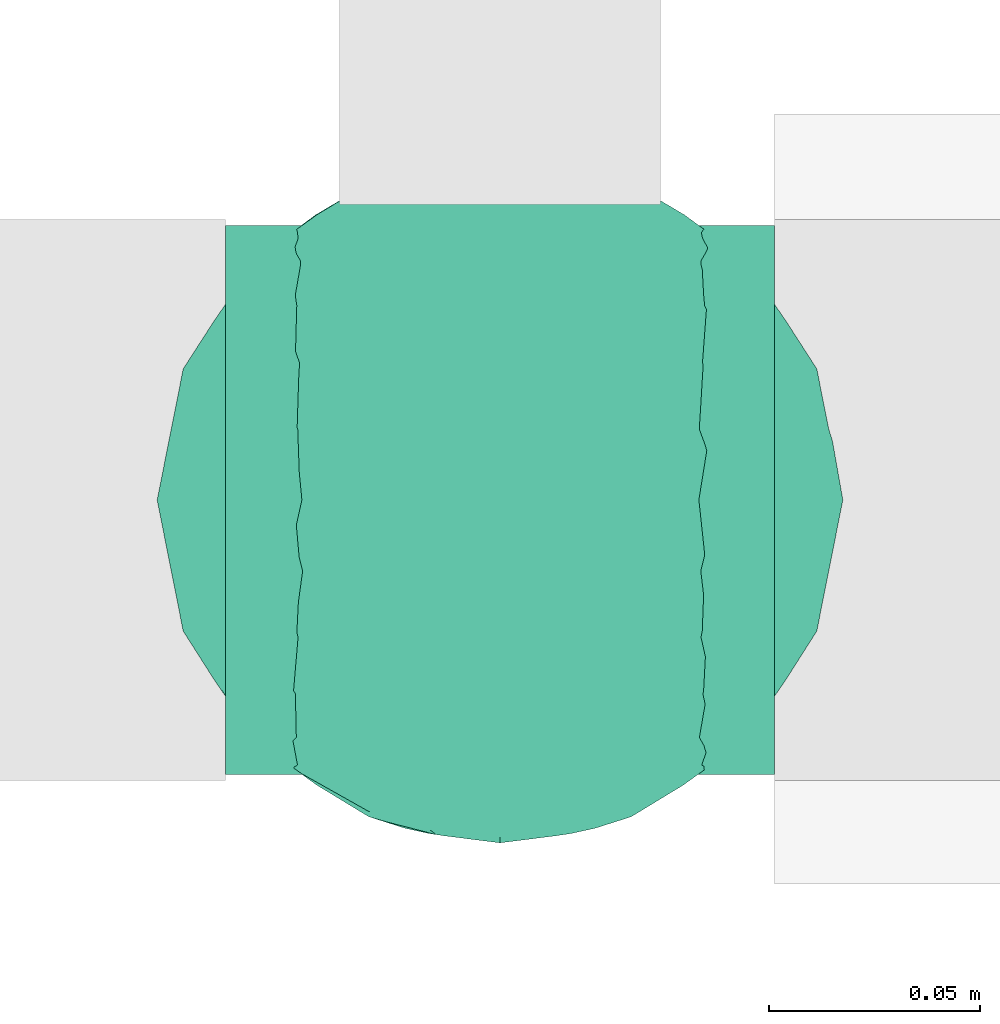
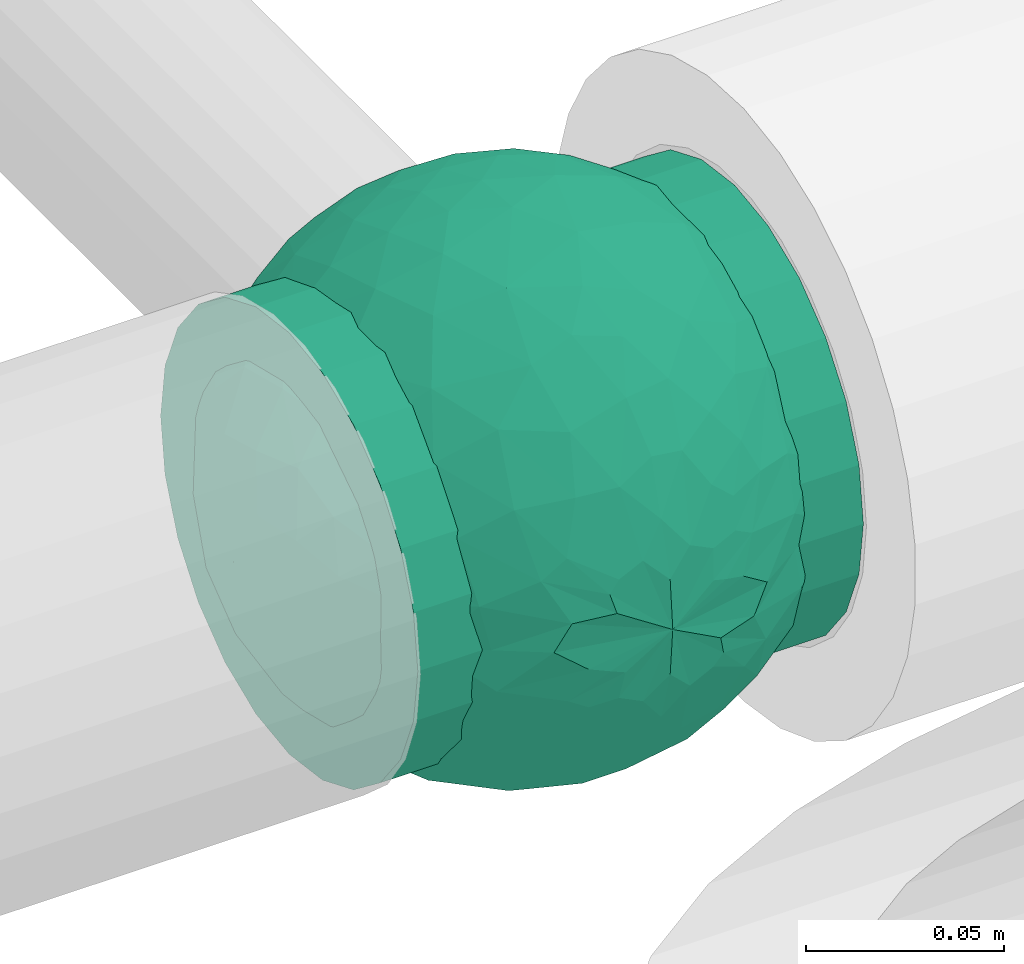
# One storey, part 784 of 827: 1 flow fitting.
"""IFC2X3 building model written with IfcOpenShell, lengths in millimetres."""

from ifc_helpers import new_model, entity, si_unit, converted_unit, derived_unit, direction, frame, origin, place, context, subcontext, project, spatial, faceted_brep, source, transform, mapped, material, material_list, type_object, type_shapes, element, save


model = new_model("IFC2X3")

# Units and contexts
model_context = context("Model", 3, precision=0.01, world=origin(), true_north=direction((6.12303176911189e-17, 1.0)))
body_context = subcontext(model_context, "Body", "Model", "MODEL_VIEW")
ifc_project = project(units=[si_unit("LENGTHUNIT", "METRE", prefix="MILLI"), si_unit("AREAUNIT", "SQUARE_METRE"), si_unit("VOLUMEUNIT", "CUBIC_METRE"), converted_unit("PLANEANGLEUNIT", "DEGREE", entity("IfcRatioMeasure", 0.0174532925199433), si_unit("PLANEANGLEUNIT", "RADIAN"), dimensions=[0, 0, 0, 0, 0, 0, 0]), si_unit("MASSUNIT", "GRAM", prefix="KILO"), derived_unit("MASSDENSITYUNIT", [(si_unit("MASSUNIT", "GRAM", prefix="KILO"), 1), (si_unit("LENGTHUNIT", "METRE"), -3)]), derived_unit("MOMENTOFINERTIAUNIT", [(si_unit("LENGTHUNIT", "METRE"), 4)]), si_unit("TIMEUNIT", "SECOND"), si_unit("FREQUENCYUNIT", "HERTZ"), si_unit("THERMODYNAMICTEMPERATUREUNIT", "DEGREE_CELSIUS"), derived_unit("THERMALTRANSMITTANCEUNIT", [(si_unit("MASSUNIT", "GRAM", prefix="KILO"), 1), (si_unit("THERMODYNAMICTEMPERATUREUNIT", "KELVIN"), -1), (si_unit("TIMEUNIT", "SECOND"), -3)]), derived_unit("VOLUMETRICFLOWRATEUNIT", [(si_unit("LENGTHUNIT", "METRE"), 3), (si_unit("TIMEUNIT", "SECOND"), -1)]), derived_unit("MASSFLOWRATEUNIT", [(si_unit("MASSUNIT", "GRAM", prefix="KILO"), 1), (si_unit("TIMEUNIT", "SECOND"), -1)]), derived_unit("ROTATIONALFREQUENCYUNIT", [(si_unit("TIMEUNIT", "SECOND"), -1)]), si_unit("ELECTRICCURRENTUNIT", "AMPERE"), si_unit("ELECTRICVOLTAGEUNIT", "VOLT"), si_unit("POWERUNIT", "WATT"), si_unit("FORCEUNIT", "NEWTON", prefix="KILO"), si_unit("ILLUMINANCEUNIT", "LUX"), si_unit("LUMINOUSFLUXUNIT", "LUMEN"), si_unit("LUMINOUSINTENSITYUNIT", "CANDELA"), derived_unit("USERDEFINED", [(si_unit("MASSUNIT", "GRAM", prefix="KILO"), -1), (si_unit("LENGTHUNIT", "METRE"), -2), (si_unit("TIMEUNIT", "SECOND"), 3), (si_unit("LUMINOUSFLUXUNIT", "LUMEN"), 1)]), derived_unit("LINEARVELOCITYUNIT", [(si_unit("LENGTHUNIT", "METRE"), 1), (si_unit("TIMEUNIT", "SECOND"), -1)]), si_unit("PRESSUREUNIT", "PASCAL"), derived_unit("USERDEFINED", [(si_unit("LENGTHUNIT", "METRE"), -2), (si_unit("MASSUNIT", "GRAM", prefix="KILO"), 1), (si_unit("TIMEUNIT", "SECOND"), -2)]), derived_unit("LINEARFORCEUNIT", [(si_unit("MASSUNIT", "GRAM", prefix="KILO"), 1), (si_unit("LENGTHUNIT", "METRE"), 1), (si_unit("TIMEUNIT", "SECOND"), -2), (si_unit("LENGTHUNIT", "METRE"), -1)]), derived_unit("PLANARFORCEUNIT", [(si_unit("MASSUNIT", "GRAM", prefix="KILO"), 1), (si_unit("LENGTHUNIT", "METRE"), 1), (si_unit("TIMEUNIT", "SECOND"), -2), (si_unit("LENGTHUNIT", "METRE"), -2)])], contexts=[model_context])

# Site, building, storey
site_placement = place(None, origin())
site = spatial("IfcSite", under=ifc_project, at=site_placement, CompositionType="ELEMENT")
building_placement = place(site_placement, origin())
building = spatial("IfcBuilding", under=site, at=building_placement, CompositionType="ELEMENT")
storey_placement = place(building_placement, frame((0.0, 0.0, 28200.0)))
storey = spatial("IfcBuildingStorey", under=building, at=storey_placement, Name="08", CompositionType="ELEMENT", Elevation=28200.0)

# Flow fitting
ifc_material_1 = material()
ifc_material_2 = material(Name="ADSK_")
ifc_material_list = material_list([ifc_material_1, ifc_material_2])
pipe_fitting_type = type_object("IfcPipeFittingType", Name="ADSK_2", PredefinedType="NOTDEFINED", material=ifc_material_list)
shared_shape = source(origin(), body_context, "Body", "Brep", [
    faceted_brep([(-65.0, 32.5, -56.29), (-65.0, 16.82, -62.79), (-65.0, 0.0, -65.0), (-65.0, -16.82, -62.79), (-65.0, -32.5, -56.29), (-65.0, -45.96, -45.96), (-65.0, -56.29, -32.5), (-65.0, -59.54, -24.66), (-65.0, -62.79, -16.82), (-65.0, -63.89, -8.41), (-65.0, -65.0, 0.0), (-65.0, -63.89, 8.41), (-65.0, -62.79, 16.82), (-65.0, -59.54, 24.66), (-65.0, -56.29, 32.5), (-65.0, -45.96, 45.96), (-65.0, -32.5, 56.29), (-65.0, -16.82, 62.79), (-65.0, 0.0, 65.0), (-65.0, 16.82, 62.79), (-65.0, 32.5, 56.29), (-65.0, 45.96, 45.96), (-65.0, 56.29, 32.5), (-65.0, 62.79, 16.82), (-65.0, 65.0, 0.0), (-65.0, 62.79, -16.82), (-65.0, 56.29, -32.5), (-65.0, 45.96, -45.96), (65.0, 0.0, -65.0), (65.0, 16.82, -62.79), (65.0, 32.5, -56.29), (65.0, 45.96, -45.96), (65.0, 56.29, -32.5), (65.0, 62.79, -16.82), (65.0, 65.0, 0.0), (65.0, 62.79, 16.82), (65.0, 56.29, 32.5), (65.0, 45.96, 45.96), (65.0, 32.5, 56.29), (65.0, 16.82, 62.79), (65.0, 0.0, 65.0), (65.0, -16.82, 62.79), (65.0, -32.5, 56.29), (65.0, -45.96, 45.96), (65.0, -56.29, 32.5), (65.0, -59.54, 24.66), (65.0, -62.79, 16.82), (65.0, -63.89, 8.41), (65.0, -65.0, 0.0), (65.0, -63.89, -8.41), (65.0, -62.79, -16.82), (65.0, -59.54, -24.66), (65.0, -56.29, -32.5), (65.0, -45.96, -45.96), (65.0, -32.5, -56.29), (65.0, -16.82, -62.79), (32.82, -63.85, 12.15), (33.91, -64.43, 6.07), (26.75, -60.95, 22.58), (29.78, -62.4, 17.36), (6.19, -55.12, 34.45), (35.0, -65.0, 0.0), (17.61, -57.53, 30.24), (11.9, -56.33, 32.35), (-17.62, -57.54, 30.24), (-26.75, -60.96, 22.57), (-32.82, -63.86, 12.15), (-33.91, -64.43, 6.07), (-35.0, -65.0, 0.0), (-29.79, -62.41, 17.36), (-11.91, -56.33, 32.35), (-6.2, -55.12, 34.45), (-0.01, -55.12, 34.45), (33.91, -64.43, -6.07), (32.82, -63.85, -12.15), (6.19, -55.12, -34.45), (-33.91, -64.43, -6.07), (17.61, -57.53, -30.24), (11.9, -56.33, -32.35), (29.78, -62.4, -17.36), (26.75, -60.95, -22.58), (-6.2, -55.12, -34.45), (-11.91, -56.33, -32.35), (-17.62, -57.54, -30.24), (-26.75, -60.96, -22.57), (-0.01, -55.12, -34.45), (-29.79, -62.41, -17.36), (-32.82, -63.86, -12.15), (0.0, -70.0, -35.0), (9.06, -70.0, -33.81), (17.5, -70.0, -30.31), (24.75, -70.0, -24.75), (30.31, -70.0, -17.5), (33.81, -70.0, -9.06), (35.0, -70.0, 0.0), (33.81, -70.0, 9.06), (30.31, -70.0, 17.5), (24.75, -70.0, 24.75), (17.5, -70.0, 30.31), (9.06, -70.0, 33.81), (0.0, -70.0, 35.0), (-9.06, -70.0, 33.81), (-17.5, -70.0, 30.31), (-24.75, -70.0, 24.75), (-30.31, -70.0, 17.5), (-33.81, -70.0, 9.06), (-35.0, -70.0, 0.0), (-33.81, -70.0, -9.06), (-30.31, -70.0, -17.5), (-24.75, -70.0, -24.75), (-17.5, -70.0, -30.31), (-9.06, -70.0, -33.81)], [[[0, 1, 2, 3, 4, 5, 6, 7, 8, 9, 10, 11, 12, 13, 14, 15, 16, 17, 18, 19, 20, 21, 22, 23, 24, 25, 26, 27]], [[28, 29, 30, 31, 32, 33, 34, 35, 36, 37, 38, 39, 40, 41, 42, 43, 44, 45, 46, 47, 48, 49, 50, 51, 52, 53, 54, 55]], [[47, 46, 56]], [[48, 47, 57]], [[46, 58, 59, 56]], [[44, 43, 60]], [[48, 57, 61]], [[58, 45, 62]], [[44, 60, 63, 62]], [[47, 56, 57]], [[43, 15, 60]], [[62, 45, 44]], [[64, 13, 65]], [[66, 11, 67]], [[68, 67, 10]], [[12, 66, 69, 65]], [[14, 64, 70, 71]], [[58, 46, 45]], [[14, 13, 64]], [[14, 71, 15]], [[65, 13, 12]], [[15, 71, 72, 60]], [[10, 67, 11]], [[66, 12, 11]], [[43, 42, 16, 15]], [[18, 17, 41, 40]], [[17, 16, 42, 41]], [[19, 18, 40, 39]], [[36, 35, 23, 22]], [[21, 20, 38, 37]], [[22, 21, 37, 36]], [[39, 38, 20, 19]], [[24, 23, 35, 34]], [[24, 34, 33, 25]], [[26, 32, 31, 27]], [[48, 73, 49]], [[25, 33, 32, 26]], [[28, 55, 3, 2]], [[1, 0, 30, 29]], [[2, 1, 29, 28]], [[30, 0, 27, 31]], [[54, 4, 3, 55]], [[74, 50, 49]], [[54, 53, 5, 4]], [[53, 52, 75]], [[10, 76, 68]], [[52, 77, 78, 75]], [[51, 77, 52]], [[53, 75, 5]], [[61, 73, 48]], [[50, 74, 79, 80]], [[74, 49, 73]], [[77, 51, 80]], [[50, 80, 51]], [[6, 81, 82, 83]], [[84, 8, 7]], [[6, 5, 81]], [[84, 7, 83]], [[5, 75, 85, 81]], [[8, 84, 86, 87]], [[9, 87, 76]], [[87, 9, 8]], [[76, 10, 9]], [[7, 6, 83]], [[88, 89, 90, 91, 92, 93, 94, 95, 96, 97, 98, 99, 100, 101, 102, 103, 104, 105, 106, 107, 108, 109, 110, 111]], [[106, 105, 67]], [[65, 104, 103]], [[105, 104, 66]], [[103, 102, 64]], [[94, 57, 95]], [[106, 67, 68]], [[66, 104, 65, 69]], [[70, 64, 102]], [[64, 65, 103]], [[100, 60, 72, 71]], [[63, 60, 99]], [[101, 70, 102]], [[63, 98, 62]], [[101, 71, 70]], [[60, 100, 99]], [[100, 71, 101]], [[58, 97, 96]], [[98, 97, 62]], [[56, 96, 95]], [[98, 63, 99]], [[97, 58, 62]], [[105, 66, 67]], [[95, 57, 56]], [[59, 58, 96, 56]], [[57, 94, 61]], [[94, 93, 73]], [[80, 92, 91]], [[93, 92, 74]], [[91, 90, 77]], [[106, 76, 107]], [[94, 73, 61]], [[74, 92, 80, 79]], [[78, 77, 90]], [[77, 80, 91]], [[88, 81, 85, 75]], [[82, 81, 111]], [[89, 78, 90]], [[82, 110, 83]], [[89, 75, 78]], [[81, 88, 111]], [[88, 75, 89]], [[108, 84, 109]], [[109, 83, 110]], [[107, 87, 108]], [[110, 82, 111]], [[109, 84, 83]], [[93, 74, 73]], [[107, 76, 87]], [[86, 84, 108, 87]], [[76, 106, 68]]]),
    faceted_brep([(-26.57, 76.36, -8.07), (-32.83, 71.49, -20.33), (-47.03, 64.85, -13.55), (22.24, -77.88, -6.48), (0.0, -81.25, 0.0), (14.57, -79.42, -9.02), (-19.55, 43.65, -65.68), (-6.7, 41.88, -69.3), (-15.5, 23.94, -76.08), (15.55, -78.16, 0.0), (20.63, -67.73, -39.86), (17.31, -55.39, -56.87), (33.39, -55.07, -49.54), (6.89, -77.99, -21.73), (13.76, -77.98, -18.22), (0.0, -79.9, -14.73), (-69.67, 30.72, -28.35), (-63.35, 45.14, -23.48), (-60.56, 38.81, -37.79), (-44.27, 66.26, 0.0), (8.9, -68.68, -42.49), (0.0, -57.53, -57.37), (-48.93, 45.14, -46.58), (-49.03, 57.11, -30.6), (-35.46, 62.54, -37.85), (76.18, -1.07, -28.23), (78.6, -12.72, -16.17), (71.53, -15.85, -35.12), (10.46, 67.82, -43.51), (0.0, 75.3, -30.53), (6.86, 78.01, -21.66), (-10.53, -67.73, -43.64), (0.0, -75.25, -30.63), (-6.89, -77.99, -21.73), (0.0, 81.25, 0.0), (15.55, 78.16, 0.0), (22.61, 77.77, -6.46), (-12.72, -56.34, -57.14), (-5.46, -45.53, -67.07), (44.37, 62.32, -27.38), (43.44, 67.56, -12.26), (56.18, 55.82, -18.18), (-13.79, 77.96, -18.26), (-25.89, 72.59, -25.72), (-16.58, 78.16, -14.76), (75.07, 31.09, 0.0), (74.86, 27.47, -15.59), (67.53, 42.93, -14.07), (13.79, 77.96, -18.26), (12.84, 79.64, -9.7), (21.38, 75.85, -19.79), (74.72, 15.85, -27.69), (79.59, 7.96, -14.27), (43.73, -67.56, -11.18), (57.45, -57.45, 0.0), (44.27, -66.26, 0.0), (63.35, -45.14, -23.48), (61.82, -51.54, -11.09), (49.12, -59.87, -24.59), (78.16, 15.55, 0.0), (50.83, -12.03, -62.24), (35.62, -9.55, -72.4), (43.7, 11.32, -67.56), (72.48, -29.04, -22.46), (-44.38, -62.32, -27.37), (-26.83, -74.87, -16.61), (-43.44, -67.56, -12.26), (-13.76, -77.98, -18.22), (-12.85, -79.64, -9.7), (-21.39, -75.84, -19.81), (-2.49, -31.04, -75.05), (8.59, -44.22, -67.62), (-74.72, -15.85, -27.69), (-68.67, -30.94, -30.47), (-74.55, -27.6, -16.8), (-75.07, 31.09, 0.0), (-71.41, 36.12, -14.04), (-75.88, 22.59, -18.27), (-22.61, -77.77, -6.46), (-16.87, -79.04, -8.34), (28.21, -26.53, -71.43), (13.03, -29.67, -74.51), (18.2, -9.78, -78.58), (-56.42, -55.66, -17.92), (6.0, 45.8, -66.84), (0.0, 57.69, -57.22), (-78.16, -15.55, 0.0), (-79.59, -7.96, -14.27), (32.83, -71.49, -20.33), (-15.55, -78.16, 0.0), (-20.62, 67.82, -39.72), (-33.11, 50.34, -54.51), (-61.82, 51.54, -11.09), (-66.26, 44.27, 0.0), (75.07, -31.09, 0.0), (66.26, -44.27, 0.0), (-6.86, 78.01, -21.66), (0.0, 79.92, -14.67), (26.82, 74.88, -16.61), (16.85, 79.04, -8.33), (-8.98, 69.99, -40.29), (38.78, -61.98, -35.46), (48.93, -45.14, -46.58), (55.26, -48.62, -34.41), (-71.53, 15.85, -35.12), (-78.76, 7.96, -18.29), (-17.06, 58.9, -53.31), (-15.55, 78.16, 0.0), (13.32, 55.85, -57.49), (21.86, 61.99, -47.75), (-15.13, 79.31, -9.05), (26.19, -72.28, -26.28), (17.27, -77.87, -15.49), (-29.57, -28.73, -70.02), (-26.25, -43.22, -63.6), (-42.18, -36.82, -58.88), (41.25, 41.74, -56.2), (54.79, 33.3, -49.91), (40.91, 28.53, -64.14), (38.98, -38.31, -60.12), (52.67, -28.88, -54.71), (68.84, 3.22, -43.04), (66.02, 21.29, -42.31), (-42.82, 33.53, -60.37), (-55.21, 10.46, -58.69), (-57.08, 27.98, -50.61), (-56.33, -15.85, -56.37), (-55.8, -33.3, -48.77), (-66.18, -20.5, -42.45), (31.09, 75.07, 0.0), (44.27, 66.26, 0.0), (57.45, 57.45, 0.0), (-31.09, -75.07, 0.0), (-57.45, -57.45, 0.0), (1.56, 67.82, -44.72), (-1.57, -67.73, -44.86), (22.55, 72.77, -28.25), (16.53, 72.17, -33.48), (-22.52, -72.77, -28.27), (-16.58, -72.47, -32.79), (28.96, -66.23, -37.11), (62.57, -34.08, -39.05), (62.37, -15.41, -49.74), (68.82, 31.09, -29.97), (-66.06, -1.38, -47.28), (-67.87, -42.27, -14.43), (29.1, 65.34, -38.54), (33.22, 68.08, -29.37), (46.02, 49.13, -45.5), (10.35, 15.34, -79.12), (0.0, 0.22, -81.25), (-29.12, -65.31, -38.57), (-22.07, -61.55, -48.23), (-33.19, -68.12, -29.33), (-46.02, -49.17, -45.45), (-34.11, 19.17, -71.21), (-23.02, 4.97, -77.76), (-40.38, 0.85, -70.5), (2.47, 31.35, -74.92), (16.3, 35.47, -71.26), (-13.73, -8.11, -79.67), (-28.12, -13.42, -75.04), (33.83, 54.01, -50.4), (26.1, 43.46, -63.49), (24.94, -42.3, -64.73), (-16.13, -35.64, -71.21), (0.28, -15.85, -79.69), (-13.57, -22.47, -76.89), (60.35, 45.14, -30.37), (-60.34, -45.14, -30.38), (-33.99, -54.1, -50.2), (-57.45, 57.45, 0.0), (-42.67, -18.04, -66.75), (-63.99, 15.14, -47.72), (-81.25, 0.0, 0.0), (-78.16, 15.55, 0.0), (-74.66, 0.0, -32.06), (-31.09, 75.07, 0.0), (31.09, -75.07, 0.0), (56.37, 15.85, -56.33), (28.0, 13.82, -75.01), (66.26, 44.27, 0.0), (81.25, 0.0, 0.0), (78.16, -15.55, 0.0), (-66.26, -44.27, 0.0), (-75.07, -31.09, 0.0), (-44.27, -66.26, 0.0), (26.57, 76.36, 8.07), (32.83, 71.49, 20.33), (47.03, 64.85, 13.55), (-22.24, -77.88, 6.48), (-14.57, -79.42, 9.02), (19.55, 43.65, 65.68), (6.7, 41.88, 69.3), (15.5, 23.94, 76.08), (-20.63, -67.73, 39.86), (-17.31, -55.39, 56.87), (-33.39, -55.07, 49.54), (-6.89, -77.99, 21.73), (-13.76, -77.98, 18.22), (0.0, -79.9, 14.73), (69.67, 30.72, 28.35), (63.35, 45.14, 23.48), (60.56, 38.81, 37.79), (-8.9, -68.68, 42.49), (0.0, -57.53, 57.37), (48.93, 45.14, 46.58), (49.03, 57.11, 30.6), (35.46, 62.54, 37.85), (-76.18, -1.07, 28.23), (-78.6, -12.72, 16.17), (-71.53, -15.85, 35.12), (-10.46, 67.82, 43.51), (0.0, 75.3, 30.53), (-6.86, 78.01, 21.66), (10.53, -67.73, 43.64), (0.0, -75.25, 30.63), (6.89, -77.99, 21.73), (-22.61, 77.77, 6.46), (12.72, -56.34, 57.14), (5.46, -45.53, 67.07), (-44.37, 62.32, 27.38), (-43.44, 67.56, 12.26), (-56.18, 55.82, 18.18), (13.79, 77.96, 18.26), (25.89, 72.59, 25.72), (16.58, 78.16, 14.76), (-74.86, 27.47, 15.59), (-67.53, 42.93, 14.07), (-13.79, 77.96, 18.26), (-12.84, 79.64, 9.7), (-21.38, 75.85, 19.79), (-74.72, 15.85, 27.69), (-79.59, 7.96, 14.27), (-43.73, -67.56, 11.18), (-63.35, -45.14, 23.48), (-61.82, -51.54, 11.09), (-49.12, -59.87, 24.59), (-50.83, -12.03, 62.24), (-35.62, -9.55, 72.4), (-43.7, 11.32, 67.56), (-72.48, -29.04, 22.46), (44.38, -62.32, 27.37), (26.83, -74.87, 16.61), (43.44, -67.56, 12.26), (13.76, -77.98, 18.22), (12.85, -79.64, 9.7), (21.39, -75.84, 19.81), (2.49, -31.04, 75.05), (-8.59, -44.22, 67.62), (74.72, -15.85, 27.69), (68.67, -30.94, 30.47), (74.55, -27.6, 16.8), (71.41, 36.12, 14.04), (75.88, 22.59, 18.27), (22.61, -77.77, 6.46), (16.87, -79.04, 8.34), (-28.21, -26.53, 71.43), (-13.03, -29.67, 74.51), (-18.2, -9.78, 78.58), (56.42, -55.66, 17.92), (-6.0, 45.8, 66.84), (0.0, 57.69, 57.22), (78.78, -14.01, 14.13), (-32.83, -71.49, 20.33), (20.62, 67.82, 39.72), (33.11, 50.34, 54.51), (61.82, 51.54, 11.09), (6.86, 78.01, 21.66), (0.0, 79.92, 14.67), (-26.82, 74.88, 16.61), (-16.85, 79.04, 8.33), (8.98, 69.99, 40.29), (-38.78, -61.98, 35.46), (-48.93, -45.14, 46.58), (-55.26, -48.62, 34.41), (71.53, 15.85, 35.12), (78.76, 7.96, 18.29), (17.06, 58.9, 53.31), (-13.32, 55.85, 57.49), (-21.86, 61.99, 47.75), (15.13, 79.31, 9.05), (-26.19, -72.28, 26.28), (-17.27, -77.87, 15.49), (29.57, -28.73, 70.02), (26.25, -43.22, 63.6), (42.18, -36.82, 58.88), (-41.25, 41.74, 56.2), (-54.79, 33.3, 49.91), (-40.91, 28.53, 64.14), (-38.98, -38.31, 60.12), (-52.67, -28.88, 54.71), (-68.84, 3.22, 43.04), (-66.02, 21.29, 42.31), (42.82, 33.53, 60.37), (55.21, 10.46, 58.69), (57.08, 27.98, 50.61), (56.33, -15.85, 56.37), (55.8, -33.3, 48.77), (66.18, -20.5, 42.45), (-1.56, 67.82, 44.72), (1.57, -67.73, 44.86), (-22.55, 72.77, 28.25), (-16.53, 72.17, 33.48), (22.52, -72.77, 28.27), (16.58, -72.47, 32.79), (-28.96, -66.23, 37.11), (-62.57, -34.08, 39.05), (-62.37, -15.41, 49.74), (-68.82, 31.09, 29.97), (66.06, -1.38, 47.28), (67.87, -42.27, 14.43), (-29.1, 65.34, 38.54), (-33.22, 68.08, 29.37), (-46.02, 49.13, 45.5), (-10.35, 15.34, 79.12), (0.0, 0.22, 81.25), (29.12, -65.31, 38.57), (22.07, -61.55, 48.23), (33.19, -68.12, 29.33), (46.02, -49.17, 45.45), (34.11, 19.17, 71.21), (23.02, 4.97, 77.76), (40.38, 0.85, 70.5), (-2.47, 31.35, 74.92), (-16.3, 35.47, 71.26), (13.73, -8.11, 79.67), (28.12, -13.42, 75.04), (-33.83, 54.01, 50.4), (-26.1, 43.46, 63.49), (-24.94, -42.3, 64.73), (16.13, -35.64, 71.21), (-0.28, -15.85, 79.69), (13.57, -22.47, 76.89), (-60.35, 45.14, 30.37), (60.34, -45.14, 30.38), (33.99, -54.1, 50.2), (42.67, -18.04, 66.75), (63.99, 15.14, 47.72), (74.66, 0.0, 32.06), (-56.37, 15.85, 56.33), (-28.0, 13.82, 75.01)], [[[0, 1, 2]], [[3, 4, 5]], [[6, 7, 8]], [[4, 3, 9]], [[10, 11, 12]], [[13, 14, 4]], [[13, 4, 15]], [[16, 17, 18]], [[19, 0, 2]], [[20, 21, 11]], [[22, 23, 24]], [[25, 26, 27]], [[28, 29, 30]], [[31, 32, 33]], [[34, 35, 36]], [[37, 38, 21]], [[39, 40, 41]], [[42, 43, 44]], [[45, 46, 47]], [[30, 34, 48]], [[49, 50, 48]], [[51, 46, 52]], [[53, 54, 55]], [[56, 57, 58]], [[46, 59, 52]], [[60, 61, 62]], [[27, 26, 63]], [[64, 65, 66]], [[67, 68, 69]], [[38, 70, 71]], [[72, 73, 74]], [[15, 33, 32]], [[75, 76, 77]], [[78, 65, 79]], [[80, 81, 82]], [[64, 66, 83]], [[84, 7, 85]], [[74, 86, 87]], [[88, 53, 3]], [[4, 89, 78]], [[24, 90, 91]], [[92, 76, 93]], [[94, 95, 63]], [[96, 34, 97]], [[36, 98, 99]], [[96, 42, 34]], [[96, 100, 90]], [[101, 102, 103]], [[77, 104, 105]], [[90, 106, 91]], [[34, 0, 107]], [[84, 85, 108]], [[109, 108, 28]], [[0, 110, 1]], [[14, 111, 112]], [[97, 30, 29]], [[39, 98, 40]], [[67, 33, 4]], [[113, 114, 115]], [[116, 117, 118]], [[119, 60, 120]], [[121, 122, 51]], [[123, 124, 125]], [[126, 127, 128]], [[129, 40, 36]], [[130, 131, 40]], [[132, 66, 78]], [[133, 83, 66]], [[97, 29, 96]], [[28, 108, 134]], [[100, 96, 29]], [[44, 34, 42]], [[15, 32, 13]], [[32, 31, 135]], [[20, 13, 32]], [[112, 4, 14]], [[48, 136, 137]], [[96, 90, 42]], [[90, 24, 43]], [[68, 67, 4]], [[67, 138, 139]], [[13, 10, 14]], [[140, 101, 111]], [[53, 58, 57]], [[141, 102, 120]], [[27, 142, 121]], [[46, 51, 143]], [[23, 2, 1]], [[125, 18, 22]], [[124, 126, 144]], [[73, 145, 74]], [[30, 137, 28]], [[28, 137, 109]], [[146, 147, 148]], [[149, 150, 8]], [[151, 152, 139]], [[152, 114, 37]], [[151, 153, 154]], [[155, 156, 157]], [[158, 84, 159]], [[156, 8, 150]], [[156, 160, 161]], [[155, 124, 123]], [[162, 116, 163]], [[119, 80, 60]], [[12, 102, 101]], [[81, 164, 71]], [[91, 123, 22]], [[100, 106, 90]], [[70, 38, 165]], [[81, 70, 166]], [[167, 113, 161]], [[156, 161, 157]], [[131, 47, 41]], [[36, 40, 98]], [[148, 39, 168]], [[146, 136, 147]], [[143, 117, 168]], [[146, 162, 109]], [[99, 34, 36]], [[133, 145, 83]], [[78, 66, 65]], [[154, 64, 169]], [[151, 138, 153]], [[115, 127, 126]], [[151, 170, 152]], [[79, 4, 78]], [[134, 100, 29]], [[85, 7, 106]], [[85, 106, 100]], [[91, 106, 6]], [[123, 6, 155]], [[91, 22, 24]], [[22, 18, 23]], [[43, 24, 1]], [[92, 17, 76]], [[1, 24, 23]], [[17, 2, 23]], [[92, 171, 2]], [[110, 0, 34]], [[6, 123, 91]], [[157, 161, 172]], [[144, 126, 128]], [[123, 125, 22]], [[124, 173, 125]], [[104, 16, 18]], [[18, 125, 173]], [[23, 18, 17]], [[105, 174, 175]], [[76, 17, 16]], [[105, 176, 87]], [[77, 175, 75]], [[176, 105, 104]], [[77, 76, 16]], [[76, 75, 93]], [[93, 171, 92]], [[177, 0, 19]], [[2, 17, 92]], [[104, 77, 16]], [[175, 77, 105]], [[3, 53, 178]], [[53, 88, 58]], [[88, 3, 5]], [[101, 58, 88]], [[56, 103, 141]], [[111, 101, 88]], [[101, 140, 12]], [[10, 20, 11]], [[119, 102, 12]], [[71, 70, 81]], [[119, 164, 80]], [[164, 12, 11]], [[80, 82, 61]], [[51, 25, 121]], [[119, 120, 102]], [[13, 20, 10]], [[20, 32, 135]], [[60, 142, 120]], [[56, 58, 103]], [[142, 141, 120]], [[63, 141, 27]], [[121, 60, 179]], [[141, 142, 27]], [[60, 121, 142]], [[122, 121, 179]], [[117, 122, 179]], [[143, 51, 122]], [[117, 179, 118]], [[168, 117, 148]], [[62, 118, 179]], [[159, 118, 180]], [[117, 143, 122]], [[143, 168, 47]], [[41, 47, 168]], [[47, 131, 181]], [[47, 46, 143]], [[46, 45, 59]], [[59, 182, 52]], [[26, 52, 182]], [[25, 51, 52]], [[26, 182, 183]], [[95, 57, 63]], [[26, 25, 52]], [[121, 25, 27]], [[94, 63, 26]], [[141, 63, 56]], [[53, 57, 54]], [[54, 57, 95]], [[63, 57, 56]], [[39, 41, 168]], [[41, 40, 131]], [[12, 164, 119]], [[164, 11, 71]], [[11, 21, 71]], [[38, 71, 21]], [[21, 135, 37]], [[38, 37, 165]], [[152, 37, 31]], [[165, 37, 114]], [[139, 31, 33]], [[151, 154, 170]], [[31, 139, 152]], [[67, 139, 33]], [[113, 165, 114]], [[167, 161, 160]], [[114, 170, 115]], [[172, 161, 113]], [[127, 115, 154]], [[172, 115, 126]], [[115, 172, 113]], [[157, 126, 124]], [[126, 157, 172]], [[124, 155, 157]], [[8, 156, 155]], [[160, 156, 150]], [[6, 8, 155]], [[8, 158, 149]], [[154, 169, 127]], [[128, 73, 72]], [[73, 127, 169]], [[176, 144, 128]], [[176, 128, 72]], [[173, 144, 104]], [[115, 170, 154]], [[114, 152, 170]], [[127, 73, 128]], [[73, 169, 145]], [[83, 145, 169]], [[145, 133, 184]], [[145, 185, 74]], [[74, 185, 86]], [[87, 86, 174]], [[105, 87, 174]], [[74, 87, 72]], [[64, 83, 169]], [[66, 132, 186]], [[167, 166, 70]], [[164, 81, 80]], [[149, 82, 150]], [[80, 61, 60]], [[82, 180, 61]], [[62, 180, 118]], [[112, 88, 5]], [[140, 14, 10]], [[166, 160, 150]], [[165, 167, 70]], [[150, 82, 166]], [[81, 166, 82]], [[167, 165, 113]], [[166, 167, 160]], [[88, 112, 111]], [[4, 112, 5]], [[144, 176, 104]], [[87, 176, 72]], [[101, 103, 58]], [[102, 141, 103]], [[60, 62, 179]], [[61, 180, 62]], [[14, 140, 111]], [[12, 140, 10]], [[48, 137, 30]], [[109, 137, 146]], [[162, 146, 148]], [[108, 85, 134]], [[109, 163, 108]], [[163, 159, 84]], [[116, 162, 148]], [[163, 109, 162]], [[163, 84, 108]], [[7, 84, 158]], [[118, 159, 163]], [[149, 159, 180]], [[8, 7, 158]], [[7, 6, 106]], [[117, 116, 148]], [[163, 116, 118]], [[98, 49, 99]], [[50, 49, 98]], [[34, 49, 48]], [[147, 98, 39]], [[136, 48, 50]], [[147, 39, 148]], [[137, 136, 146]], [[136, 50, 147]], [[98, 147, 50]], [[34, 99, 49]], [[65, 68, 79]], [[68, 65, 69]], [[153, 65, 64]], [[138, 67, 69]], [[153, 64, 154]], [[139, 138, 151]], [[138, 69, 153]], [[65, 153, 69]], [[4, 79, 68]], [[34, 30, 97]], [[4, 33, 15]], [[100, 134, 85]], [[29, 28, 134]], [[37, 135, 31]], [[20, 135, 21]], [[159, 149, 158]], [[82, 149, 180]], [[40, 129, 130]], [[186, 133, 66]], [[44, 1, 110]], [[90, 43, 42]], [[1, 44, 43]], [[34, 44, 110]], [[2, 171, 19]], [[0, 177, 107]], [[144, 173, 124]], [[18, 173, 104]], [[3, 178, 9]], [[55, 178, 53]], [[181, 45, 47]], [[94, 26, 183]], [[184, 185, 145]], [[35, 129, 36]], [[89, 132, 78]], [[187, 188, 189]], [[190, 4, 191]], [[192, 193, 194]], [[4, 190, 89]], [[195, 196, 197]], [[198, 199, 4]], [[198, 4, 200]], [[201, 202, 203]], [[130, 187, 189]], [[204, 205, 196]], [[206, 207, 208]], [[209, 210, 211]], [[212, 213, 214]], [[215, 216, 217]], [[34, 107, 218]], [[219, 220, 205]], [[221, 222, 223]], [[224, 225, 226]], [[75, 227, 228]], [[214, 34, 229]], [[230, 231, 229]], [[232, 227, 233]], [[234, 133, 186]], [[235, 236, 237]], [[227, 175, 233]], [[238, 239, 240]], [[211, 210, 241]], [[242, 243, 244]], [[245, 246, 247]], [[220, 248, 249]], [[250, 251, 252]], [[200, 217, 216]], [[45, 253, 254]], [[255, 243, 256]], [[257, 258, 259]], [[242, 244, 260]], [[261, 193, 262]], [[252, 183, 263]], [[264, 234, 190]], [[4, 9, 255]], [[208, 265, 266]], [[267, 253, 181]], [[185, 184, 241]], [[268, 34, 269]], [[218, 270, 271]], [[268, 224, 34]], [[268, 272, 265]], [[273, 274, 275]], [[254, 276, 277]], [[265, 278, 266]], [[34, 187, 35]], [[261, 262, 279]], [[280, 279, 212]], [[187, 281, 188]], [[199, 282, 283]], [[269, 214, 213]], [[221, 270, 222]], [[245, 217, 4]], [[284, 285, 286]], [[287, 288, 289]], [[290, 238, 291]], [[292, 293, 232]], [[294, 295, 296]], [[297, 298, 299]], [[177, 222, 218]], [[171, 223, 222]], [[178, 244, 255]], [[54, 260, 244]], [[269, 213, 268]], [[34, 230, 229]], [[212, 279, 300]], [[272, 268, 213]], [[226, 34, 224]], [[200, 216, 198]], [[216, 215, 301]], [[204, 198, 216]], [[229, 302, 303]], [[268, 265, 224]], [[265, 208, 225]], [[246, 245, 4]], [[245, 304, 305]], [[198, 195, 199]], [[306, 273, 282]], [[234, 237, 236]], [[307, 274, 291]], [[211, 308, 292]], [[227, 232, 309]], [[207, 189, 188]], [[296, 203, 206]], [[295, 297, 310]], [[251, 311, 252]], [[214, 303, 212]], [[212, 303, 280]], [[312, 313, 314]], [[315, 316, 194]], [[317, 318, 305]], [[318, 285, 219]], [[317, 319, 320]], [[321, 322, 323]], [[324, 261, 325]], [[322, 194, 316]], [[322, 326, 327]], [[321, 295, 294]], [[328, 287, 329]], [[290, 257, 238]], [[197, 274, 273]], [[258, 330, 249]], [[266, 294, 206]], [[272, 278, 265]], [[248, 220, 331]], [[258, 248, 332]], [[333, 284, 327]], [[322, 327, 323]], [[171, 228, 223]], [[218, 222, 270]], [[314, 221, 334]], [[312, 302, 313]], [[309, 288, 334]], [[312, 328, 280]], [[271, 34, 218]], [[54, 311, 260]], [[255, 244, 243]], [[320, 242, 335]], [[317, 304, 319]], [[286, 298, 297]], [[317, 336, 318]], [[256, 4, 255]], [[300, 272, 213]], [[262, 193, 278]], [[262, 278, 272]], [[266, 278, 192]], [[294, 192, 321]], [[266, 206, 208]], [[206, 203, 207]], [[225, 208, 188]], [[267, 202, 253]], [[188, 208, 207]], [[202, 189, 207]], [[267, 131, 189]], [[281, 187, 34]], [[192, 294, 266]], [[323, 327, 337]], [[310, 297, 299]], [[294, 296, 206]], [[295, 338, 296]], [[276, 201, 203]], [[203, 296, 338]], [[207, 203, 202]], [[277, 182, 59]], [[253, 202, 201]], [[263, 250, 252]], [[254, 59, 45]], [[339, 277, 276]], [[254, 253, 201]], [[253, 45, 181]], [[181, 131, 267]], [[129, 187, 130]], [[189, 202, 267]], [[276, 254, 201]], [[59, 254, 277]], [[190, 234, 132]], [[234, 264, 237]], [[272, 300, 262]], [[264, 190, 191]], [[273, 237, 264]], [[235, 275, 307]], [[282, 273, 264]], [[273, 306, 197]], [[195, 204, 196]], [[290, 274, 197]], [[249, 248, 258]], [[290, 330, 257]], [[330, 197, 196]], [[257, 259, 239]], [[232, 209, 292]], [[290, 291, 274]], [[198, 204, 195]], [[204, 216, 301]], [[238, 308, 291]], [[235, 237, 275]], [[308, 307, 291]], [[241, 307, 211]], [[292, 238, 340]], [[307, 308, 211]], [[238, 292, 308]], [[293, 292, 340]], [[288, 293, 340]], [[309, 232, 293]], [[288, 340, 289]], [[334, 288, 314]], [[240, 289, 340]], [[325, 289, 341]], [[288, 309, 293]], [[309, 334, 228]], [[223, 228, 334]], [[228, 171, 93]], [[228, 227, 309]], [[227, 75, 175]], [[175, 174, 233]], [[210, 233, 174]], [[209, 232, 233]], [[210, 174, 86]], [[184, 236, 241]], [[210, 209, 233]], [[292, 209, 211]], [[185, 241, 210]], [[307, 241, 235]], [[234, 236, 133]], [[133, 236, 184]], [[241, 236, 235]], [[221, 223, 334]], [[222, 177, 19]], [[197, 330, 290]], [[330, 196, 249]], [[196, 205, 249]], [[220, 249, 205]], [[205, 301, 219]], [[220, 219, 331]], [[318, 219, 215]], [[331, 219, 285]], [[305, 215, 217]], [[317, 320, 336]], [[215, 305, 318]], [[245, 305, 217]], [[284, 331, 285]], [[333, 327, 326]], [[285, 336, 286]], [[337, 327, 284]], [[298, 286, 320]], [[337, 286, 297]], [[286, 337, 284]], [[323, 297, 295]], [[297, 323, 337]], [[295, 321, 323]], [[194, 322, 321]], [[326, 322, 316]], [[192, 194, 321]], [[194, 324, 315]], [[320, 335, 298]], [[299, 251, 250]], [[251, 298, 335]], [[339, 310, 299]], [[339, 299, 250]], [[338, 310, 276]], [[286, 336, 320]], [[285, 318, 336]], [[298, 251, 299]], [[251, 335, 311]], [[260, 311, 335]], [[311, 54, 95]], [[311, 94, 252]], [[252, 94, 183]], [[182, 277, 263]], [[182, 263, 183]], [[339, 263, 277]], [[242, 260, 335]], [[244, 178, 55]], [[333, 332, 248]], [[330, 258, 257]], [[315, 259, 316]], [[257, 239, 238]], [[259, 341, 239]], [[240, 341, 289]], [[283, 264, 191]], [[306, 199, 195]], [[332, 326, 316]], [[331, 333, 248]], [[316, 259, 332]], [[258, 332, 259]], [[333, 331, 284]], [[332, 333, 326]], [[264, 283, 282]], [[4, 283, 191]], [[310, 339, 276]], [[263, 339, 250]], [[273, 275, 237]], [[274, 307, 275]], [[238, 240, 340]], [[239, 341, 240]], [[199, 306, 282]], [[197, 306, 195]], [[229, 303, 214]], [[280, 303, 312]], [[328, 312, 314]], [[279, 262, 300]], [[280, 329, 279]], [[329, 325, 261]], [[287, 328, 314]], [[329, 280, 328]], [[329, 261, 279]], [[193, 261, 324]], [[289, 325, 329]], [[315, 325, 341]], [[194, 193, 324]], [[193, 192, 278]], [[288, 287, 314]], [[329, 287, 289]], [[270, 230, 271]], [[231, 230, 270]], [[313, 270, 221]], [[302, 229, 231]], [[313, 221, 314]], [[303, 302, 312]], [[302, 231, 313]], [[270, 313, 231]], [[34, 271, 230]], [[243, 246, 256]], [[246, 243, 247]], [[319, 243, 242]], [[304, 245, 247]], [[319, 242, 320]], [[305, 304, 317]], [[304, 247, 319]], [[243, 319, 247]], [[4, 256, 246]], [[34, 214, 269]], [[4, 217, 200]], [[4, 199, 283]], [[213, 212, 300]], [[219, 301, 215]], [[204, 301, 205]], [[325, 315, 324]], [[259, 315, 341]], [[19, 171, 222]], [[55, 54, 244]], [[226, 188, 281]], [[265, 225, 224]], [[188, 226, 225]], [[34, 226, 281]], [[189, 131, 130]], [[187, 129, 35]], [[310, 338, 295]], [[203, 338, 276]], [[190, 132, 89]], [[186, 132, 234]], [[93, 75, 228]], [[185, 210, 86]], [[95, 94, 311]], [[107, 177, 218]], [[9, 178, 255]]]),
])
type_shapes(pipe_fitting_type, [shared_shape])
flow_fitting_placement = place(storey_placement, frame((26193.91, 12315.57, 3100.0), z_axis=(0.0, 0.0, -1.0), x_axis=(1.0, 0.0, 0.0)))
element("IfcFlowFitting", 1, at=flow_fitting_placement, inside=storey, type_object=pipe_fitting_type, material=ifc_material_list, Name="ADSK_2", ObjectType="ADSK_2", context=body_context, shape_type="MappedRepresentation", body=[
    mapped(shared_shape, transform((0.0, 0.0, 0.0), scale=1.0)),
])

save(model, "model.ifc")
